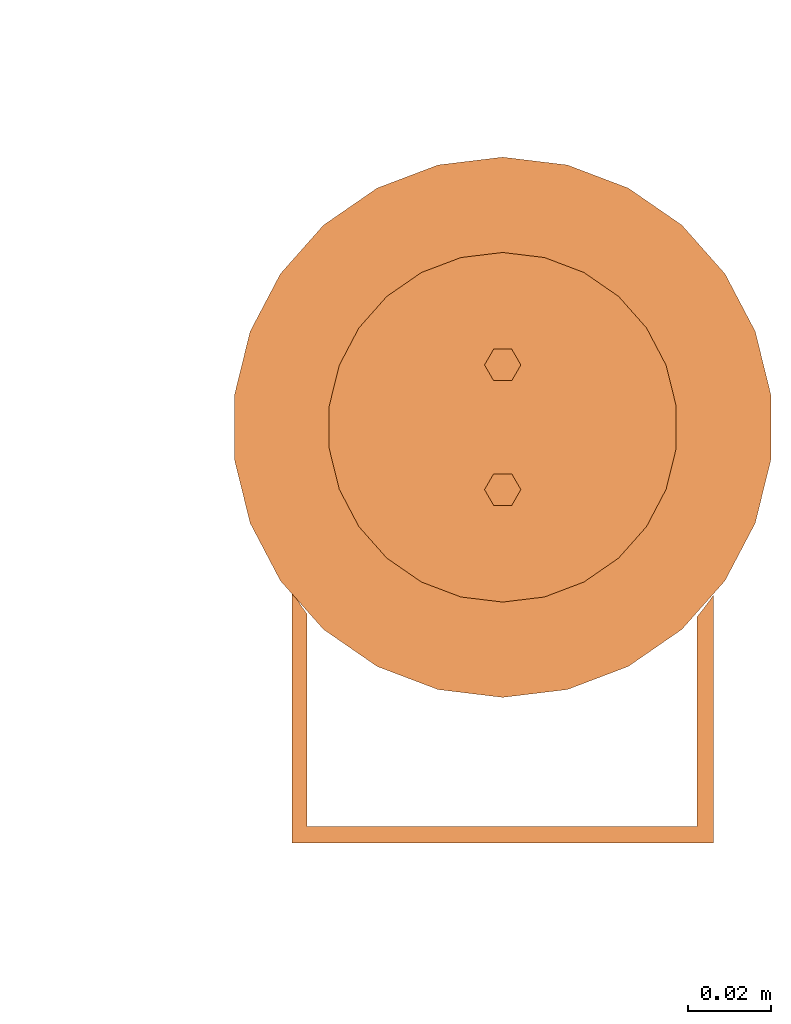
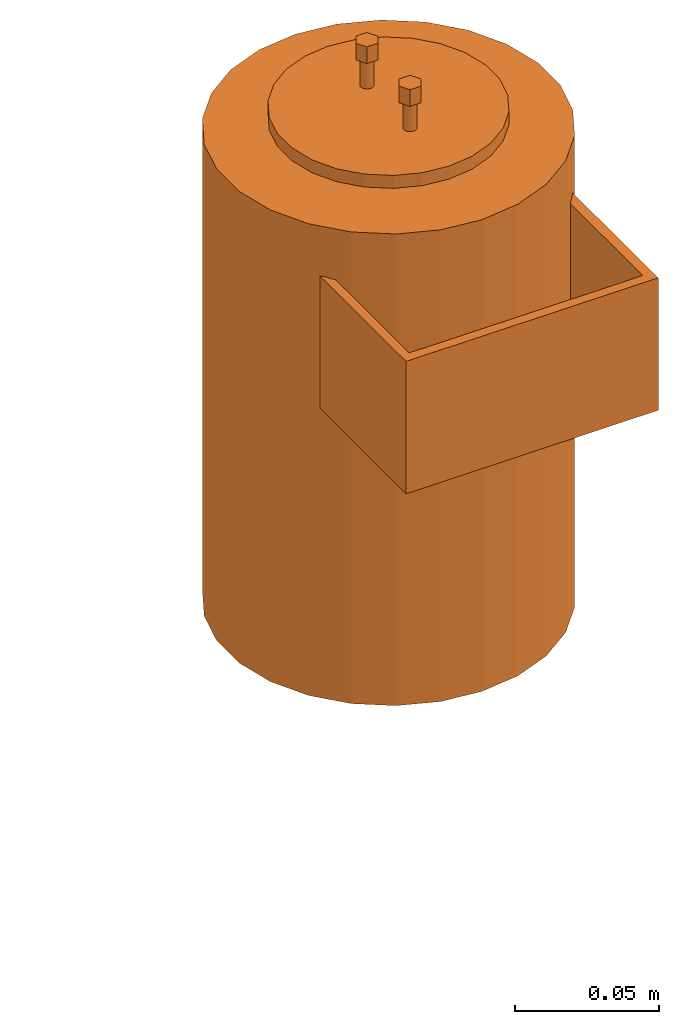
# One storey, part 2 of 3: 1 proxy.
"""IFC2X3 building model written with IfcOpenShell, lengths in millimetres."""

from ifc_helpers import new_model, entity, si_unit, converted_unit, derived_unit, direction, frame, frame_2d, origin, origin_2d_with_axis, place, context, subcontext, project, spatial, polyline, circle_curve, parameter, trimmed, segment, composite_curve, rectangle, circle, outline, extrude, source, transform, mapped, material, material_list, type_object, type_shapes, element, save


model = new_model("IFC2X3")

# Units and contexts
model_context = context("Model", 3, precision=0.01, world=origin(), true_north=direction((6.12303176911189e-17, 1.0)))
body_context = subcontext(model_context, "Body", "Model", "MODEL_VIEW")
ifc_project = project(units=[si_unit("LENGTHUNIT", "METRE", prefix="MILLI"), si_unit("AREAUNIT", "SQUARE_METRE"), si_unit("VOLUMEUNIT", "CUBIC_METRE"), converted_unit("PLANEANGLEUNIT", "DEGREE", entity("IfcRatioMeasure", 0.0174532925199433), si_unit("PLANEANGLEUNIT", "RADIAN"), dimensions=[0, 0, 0, 0, 0, 0, 0]), si_unit("MASSUNIT", "GRAM", prefix="KILO"), derived_unit("MASSDENSITYUNIT", [(si_unit("MASSUNIT", "GRAM", prefix="KILO"), 1), (si_unit("LENGTHUNIT", "METRE"), -3)]), derived_unit("MOMENTOFINERTIAUNIT", [(si_unit("LENGTHUNIT", "METRE"), 4)]), si_unit("TIMEUNIT", "SECOND"), si_unit("FREQUENCYUNIT", "HERTZ"), si_unit("THERMODYNAMICTEMPERATUREUNIT", "DEGREE_CELSIUS"), derived_unit("THERMALTRANSMITTANCEUNIT", [(si_unit("MASSUNIT", "GRAM", prefix="KILO"), 1), (si_unit("THERMODYNAMICTEMPERATUREUNIT", "KELVIN"), -1), (si_unit("TIMEUNIT", "SECOND"), -3)]), derived_unit("VOLUMETRICFLOWRATEUNIT", [(si_unit("LENGTHUNIT", "METRE"), 3), (si_unit("TIMEUNIT", "SECOND"), -1)]), derived_unit("MASSFLOWRATEUNIT", [(si_unit("MASSUNIT", "GRAM", prefix="KILO"), 1), (si_unit("TIMEUNIT", "SECOND"), -1)]), derived_unit("ROTATIONALFREQUENCYUNIT", [(si_unit("TIMEUNIT", "SECOND"), -1)]), si_unit("ELECTRICCURRENTUNIT", "AMPERE"), si_unit("ELECTRICVOLTAGEUNIT", "VOLT"), si_unit("POWERUNIT", "WATT"), si_unit("FORCEUNIT", "NEWTON", prefix="KILO"), si_unit("ILLUMINANCEUNIT", "LUX"), si_unit("LUMINOUSFLUXUNIT", "LUMEN"), si_unit("LUMINOUSINTENSITYUNIT", "CANDELA"), derived_unit("USERDEFINED", [(si_unit("MASSUNIT", "GRAM", prefix="KILO"), -1), (si_unit("LENGTHUNIT", "METRE"), -2), (si_unit("TIMEUNIT", "SECOND"), 3), (si_unit("LUMINOUSFLUXUNIT", "LUMEN"), 1)]), derived_unit("LINEARVELOCITYUNIT", [(si_unit("LENGTHUNIT", "METRE"), 1), (si_unit("TIMEUNIT", "SECOND"), -1)]), si_unit("PRESSUREUNIT", "PASCAL"), derived_unit("USERDEFINED", [(si_unit("LENGTHUNIT", "METRE"), -2), (si_unit("MASSUNIT", "GRAM", prefix="KILO"), 1), (si_unit("TIMEUNIT", "SECOND"), -2)]), derived_unit("LINEARFORCEUNIT", [(si_unit("MASSUNIT", "GRAM", prefix="KILO"), 1), (si_unit("LENGTHUNIT", "METRE"), 1), (si_unit("TIMEUNIT", "SECOND"), -2), (si_unit("LENGTHUNIT", "METRE"), -1)]), derived_unit("PLANARFORCEUNIT", [(si_unit("MASSUNIT", "GRAM", prefix="KILO"), 1), (si_unit("LENGTHUNIT", "METRE"), 1), (si_unit("TIMEUNIT", "SECOND"), -2), (si_unit("LENGTHUNIT", "METRE"), -2)])], contexts=[model_context])

# Site, building, storey
site_placement = place(None, frame((0.0, 2493.83037508239, 0.0)))
site = spatial("IfcSite", under=ifc_project, at=site_placement, CompositionType="ELEMENT")
building_placement = place(site_placement, origin())
building = spatial("IfcBuilding", under=site, at=building_placement, CompositionType="ELEMENT")
storey_placement = place(building_placement, frame((0.0, 0.0, -4200.0)))
storey = spatial("IfcBuildingStorey", under=building, at=storey_placement, CompositionType="ELEMENT", Elevation=-4200.0)

# Proxy
ifc_material_1 = material()
ifc_material_2 = material()
ifc_material_list_1 = material_list([ifc_material_1, ifc_material_2])
ifc_material_list_2 = material_list([ifc_material_1, ifc_material_2, ifc_material_2, ifc_material_2, ifc_material_1, ifc_material_1, ifc_material_2, ifc_material_2, ifc_material_2, ifc_material_2, ifc_material_1, ifc_material_2, ifc_material_1])
building_element_proxy_type = type_object("IfcBuildingElementProxyType", PredefinedType="NOTDEFINED", material=ifc_material_list_2)
shared_shape = source(origin(), body_context, "Body", "SweptSolid", [
    extrude(outline(composite_curve([segment(polyline([(-50.6190797390656, -29.6927809029152), (50.7978121434001, -29.6927809029152)]), True, "CONTINUOUS"), segment(polyline([(50.7978121434001, -29.6927809029152), (50.7978121433998, 29.9319067985824)]), True, "CONTINUOUS"), segment(trimmed(circle_curve(frame_2d((-2.96955687874301, 66.4568301858547), x_axis=(0.0, 1.0)), 65.000000000072), [parameter(230.024604883455)], [parameter(235.81118571205)], True, "PARAMETER"), False, "CONTINUOUS"), segment(polyline([(46.8412696908431, 24.6970222784423), (46.841269690843, -25.7795153544058)]), True, "CONTINUOUS"), segment(polyline([(46.841269690843, -25.7795153544058), (-47.0200020951777, -25.7795153544058)]), True, "CONTINUOUS"), segment(polyline([(-47.0200020951777, -25.7795153544058), (-47.0200020951776, 25.3991699653791)]), True, "CONTINUOUS"), segment(trimmed(circle_curve(frame_2d((5.55149190703001, 63.6253130925639), x_axis=(0.0, 1.0)), 65.0000000000321), [parameter(120.212773122666)], [parameter(126.021905105958)], True, "PARAMETER"), False, "CONTINUOUS"), segment(polyline([(-50.6190797390655, 30.916493472238), (-50.6190797390656, -29.6927809029152)]), True, "CONTINUOUS")], self_intersect=False)), frame((-70.3072190970849, 0.089366202167497, 122.95584102252), z_axis=(0.0, 0.0, 1.0), x_axis=(0.0, -1.0, 0.0)), (0.0, 0.0, 1.0), 56.2704951333589),
    extrude(rectangle(XDim=3.39416585306304, YDim=8.55329794971887, at=origin_2d_with_axis()), frame((-4.66791615948156, 0.0, -24.0560320870143), z_axis=(0.0, 0.0, 1.0), x_axis=(-1.0, 0.0, 0.0)), (0.0, 0.0, 1.0), 2.73216002599925),
    extrude(rectangle(XDim=3.39416585306304, YDim=8.55329794971887, at=origin_2d_with_axis()), frame((-9.66791615948157, 0.0, -24.0560320870143), z_axis=(0.0, 0.0, 1.0), x_axis=(-1.0, 0.0, 0.0)), (0.0, 0.0, 1.0), 2.73216002599925),
    extrude(circle(Radius=10.0, at=frame_2d((0.0, -1.61554457443259e-14), x_axis=(1.0, 0.0))), frame((15.4155732499369, 0.0, -37.0467508187846)), (0.0, 0.0, 1.0), 15.7228787577696),
    extrude(circle(Radius=30.0, at=frame_2d((1.03012309434716e-18, -4.84663372329776e-14), x_axis=(1.0, 0.0))), frame((0.0, 0.0, -21.323872061015)), (0.0, 0.0, 1.0), 18.571347291235),
    extrude(circle(Radius=42.0602756217442, at=frame_2d((4.31456406551639e-21, -6.79502500798481e-14), x_axis=(1.0, 0.0))), frame((0.0, 0.0, -2.75252476978)), (0.0, 0.0, 1.0), 2.75252476978),
    extrude(outline(polyline([(-2.18450540279827, -3.78367434705532), (2.18450540279826, -3.78367434705532), (4.36901080559654, 0.0), (2.18450540279828, 3.78367434705531), (-2.18450540279826, 3.78367434705533), (-4.36901080559655, 0.0), (-2.18450540279827, -3.78367434705532)])), frame((15.0, 0.0, 221.385080369336), z_axis=(0.0, 0.0, 1.0), x_axis=(0.0, 1.0, 0.0)), (0.0, 0.0, 1.0), 7.06354091758868),
    extrude(outline(polyline([(-2.18450540279827, -3.78367434705532), (2.18450540279826, -3.78367434705532), (4.36901080559654, 0.0), (2.18450540279828, 3.78367434705531), (-2.18450540279826, 3.78367434705533), (-4.36901080559655, 0.0), (-2.18450540279827, -3.78367434705532)])), frame((-15.0, 0.0, 221.385080369336), z_axis=(0.0, 0.0, 1.0), x_axis=(0.0, 1.0, 0.0)), (0.0, 0.0, 1.0), 7.06354091758868),
    extrude(circle(Radius=2.5, at=frame_2d((0.0, -4.03886143608143e-15), x_axis=(1.0, 0.0))), frame((15.0, 0.0, 209.294449052902), z_axis=(0.0, 0.0, 1.0), x_axis=(-1.0, 0.0, 0.0)), (0.0, 0.0, 1.0), 12.0906313164343),
    extrude(circle(Radius=2.5, at=frame_2d((0.0, -4.03886143608143e-15), x_axis=(1.0, 0.0))), frame((-15.0, 0.0, 209.294449052902)), (0.0, 0.0, 1.0), 12.0906313164343),
    extrude(circle(Radius=42.0602756217442, at=frame_2d((1.77475544914245e-20, -6.79502500798481e-14), x_axis=(1.0, 0.0))), frame((0.0, 0.0, 203.808117867585)), (0.0, 0.0, 1.0), 5.48633118531672),
    extrude(circle(Radius=35.0, at=frame_2d((-6.09992424146964e-18, -5.65440601051405e-14), x_axis=(1.0, 0.0))), frame((0.0, 0.0, 200.448097438844)), (0.0, 0.0, 1.0), 3.36002042874051),
    extrude(circle(Radius=65.0, at=frame_2d((0.0, -1.05010397338118e-13), x_axis=(1.0, 0.0))), origin(), (0.0, 0.0, 1.0), 200.448097438844),
])
type_shapes(building_element_proxy_type, [shared_shape])
proxy_placement = place(storey_placement, frame((73170.1118832777, 5606.16954061282, 1500.0), z_axis=(0.0, 0.0, 1.0), x_axis=(0.0, 1.0, 0.0)))
element("IfcBuildingElementProxy", 1, at=proxy_placement, inside=storey, type_object=building_element_proxy_type, material=ifc_material_list_1, context=body_context, shape_type="MappedRepresentation", body=[
    mapped(shared_shape, transform((0.0, 0.0, 0.0), scale=1.0)),
])

save(model, "model.ifc")
